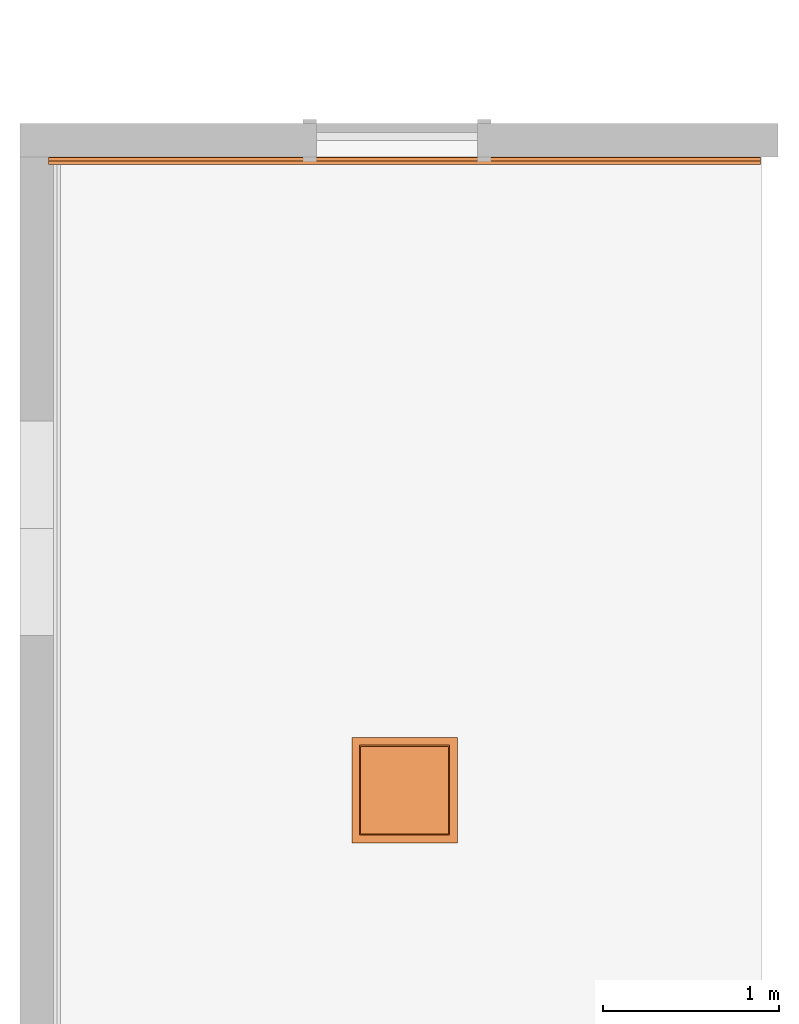
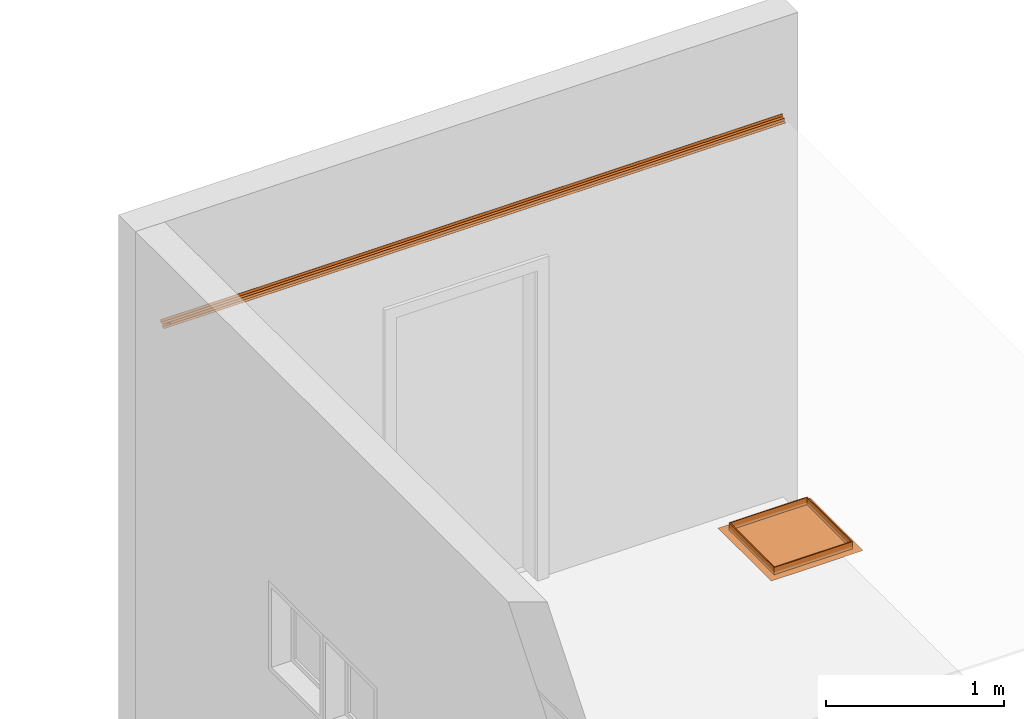
# One storey, part 5 of 5: 2 proxies.
"""IFC2X3 building model written with IfcOpenShell, lengths in millimetres."""

from ifc_helpers import new_model, entity, si_unit, converted_unit, derived_unit, direction, frame, origin, place, context, subcontext, project, spatial, faceted_brep, source, transform, mapped, material, type_object, type_shapes, element, save


model = new_model("IFC2X3")

# Units and contexts
model_context = context("Model", 3, precision=0.01, world=origin(), true_north=direction((6.12303176911189e-17, 1.0)))
body_context = subcontext(model_context, "Body", "Model", "MODEL_VIEW")
ifc_project = project(units=[si_unit("LENGTHUNIT", "METRE", prefix="MILLI"), si_unit("AREAUNIT", "SQUARE_METRE"), si_unit("VOLUMEUNIT", "CUBIC_METRE"), converted_unit("PLANEANGLEUNIT", "DEGREE", entity("IfcRatioMeasure", 0.0174532925199433), si_unit("PLANEANGLEUNIT", "RADIAN"), dimensions=[0, 0, 0, 0, 0, 0, 0]), si_unit("MASSUNIT", "GRAM", prefix="KILO"), derived_unit("MASSDENSITYUNIT", [(si_unit("MASSUNIT", "GRAM", prefix="KILO"), 1), (si_unit("LENGTHUNIT", "METRE"), -3)]), si_unit("TIMEUNIT", "SECOND"), si_unit("FREQUENCYUNIT", "HERTZ"), si_unit("THERMODYNAMICTEMPERATUREUNIT", "DEGREE_CELSIUS"), derived_unit("THERMALTRANSMITTANCEUNIT", [(si_unit("MASSUNIT", "GRAM", prefix="KILO"), 1), (si_unit("THERMODYNAMICTEMPERATUREUNIT", "KELVIN"), -1), (si_unit("TIMEUNIT", "SECOND"), -3)]), derived_unit("VOLUMETRICFLOWRATEUNIT", [(si_unit("LENGTHUNIT", "METRE"), 3), (si_unit("TIMEUNIT", "SECOND"), -1)]), si_unit("ELECTRICCURRENTUNIT", "AMPERE"), si_unit("ELECTRICVOLTAGEUNIT", "VOLT"), si_unit("POWERUNIT", "WATT"), si_unit("FORCEUNIT", "NEWTON", prefix="KILO"), si_unit("ILLUMINANCEUNIT", "LUX"), si_unit("LUMINOUSFLUXUNIT", "LUMEN"), si_unit("LUMINOUSINTENSITYUNIT", "CANDELA"), derived_unit("USERDEFINED", [(si_unit("MASSUNIT", "GRAM", prefix="KILO"), -1), (si_unit("LENGTHUNIT", "METRE"), -2), (si_unit("TIMEUNIT", "SECOND"), 3), (si_unit("LUMINOUSFLUXUNIT", "LUMEN"), 1)]), derived_unit("LINEARVELOCITYUNIT", [(si_unit("LENGTHUNIT", "METRE"), 1), (si_unit("TIMEUNIT", "SECOND"), -1)]), si_unit("PRESSUREUNIT", "PASCAL"), derived_unit("USERDEFINED", [(si_unit("LENGTHUNIT", "METRE"), -2), (si_unit("MASSUNIT", "GRAM", prefix="KILO"), 1), (si_unit("TIMEUNIT", "SECOND"), -2)])], contexts=[model_context])

# Site, building, storey
site_placement = place(None, origin())
site = spatial("IfcSite", under=ifc_project, at=site_placement, CompositionType="ELEMENT")
building_placement = place(site_placement, origin())
building = spatial("IfcBuilding", under=site, at=building_placement, CompositionType="ELEMENT")
storey_placement = place(building_placement, origin())
storey = spatial("IfcBuildingStorey", under=building, at=storey_placement, Name="Base Level", CompositionType="ELEMENT", Elevation=0.0)

# Proxies
ifc_material = material(Name="mesh")
building_element_proxy_type_1 = type_object("IfcBuildingElementProxyType", Name="Bottom Hung", PredefinedType="NOTDEFINED", material=ifc_material)
shared_shape_1 = source(origin(), body_context, "Body", "Brep", [
    faceted_brep([(50.8000000000058, 548.8, 59.5249999999756), (548.800000000014, 548.800000000001, 59.5249999999756), (548.800000000014, 50.8000000000014, 59.5249999999756), (50.8000000000058, 50.8000000000004, 59.5249999999756), (44.4499999999942, 555.149999999998, 59.5249999999756), (44.4499999999942, 44.4500000000045, 59.5249999999756), (555.150000000025, 44.4500000000056, 59.5249999999756), (555.150000000025, 555.149999999999, 59.5249999999756), (50.8000000000058, 548.8, 9.52499999997564), (50.8000000000058, 50.8000000000004, 9.52499999997564), (548.800000000014, 50.8000000000014, 9.52499999997564), (548.800000000014, 548.800000000001, 9.52499999997564), (44.4499999999942, 555.149999999998, 9.52499999997564), (555.150000000025, 555.149999999999, 9.52499999997564), (555.150000000025, 44.4500000000056, 9.52499999997564), (44.4499999999942, 44.4500000000045, 9.52499999997564), (44.4500000000115, 555.149999999999, 20.5249999999758), (44.4500000000115, 44.4500000000045, 20.5249999999758), (555.150000000025, 44.4500000000056, 20.5249999999758), (555.150000000025, 555.15, 20.5249999999758)], [[[0, 1, 2, 3], [4, 5, 6, 7]], [[8, 9, 10, 11], [12, 13, 14, 15]], [[1, 0, 8, 11]], [[2, 1, 11, 10]], [[3, 2, 10, 9]], [[0, 3, 9, 8]], [[5, 4, 16, 12, 15, 17]], [[6, 5, 17, 15, 14, 18]], [[7, 6, 18, 14, 13, 19]], [[4, 7, 19, 13, 12, 16]]], outer=[[False, True], [False, True], [True], [True], [True], [True], [True], [True], [True], [True]]),
    faceted_brep([(50.8000000000058, 548.8, 3.174999999976), (548.800000000014, 548.800000000001, 3.174999999976), (548.800000000014, 50.8000000000014, 3.174999999976), (50.8000000000058, 50.8000000000004, 3.174999999976), (50.8000000000058, 548.8, 9.52499999997564), (50.8000000000058, 50.8000000000004, 9.52499999997564), (548.800000000014, 50.8000000000014, 9.52499999997564), (548.800000000014, 548.800000000001, 9.52499999997564)], [[[0, 1, 2, 3]], [[4, 5, 6, 7]], [[5, 4, 0, 3]], [[6, 5, 3, 2]], [[7, 6, 2, 1]], [[4, 7, 1, 0]]]),
    faceted_brep([(50.8000000000231, 548.799999999992, 9.52499999995127), (50.8000000000231, 548.799999999992, 0.0), (548.800000000014, 548.799999999993, 0.0), (548.800000000014, 548.799999999993, 9.52499999995073), (548.800000000014, 50.8000000000096, 0.0), (548.800000000014, 50.8000000000096, 9.52499999995073), (50.8000000000231, 50.8000000000085, 0.0), (50.8000000000231, 50.8000000000085, 9.52499999995073), (586.900000000014, 586.900000000001, 0.0), (586.900000000014, 12.7000000000014, 0.0), (12.7000000000058, 12.7000000000004, 0.0), (12.7000000000058, 586.9, 0.0), (0.0, 599.6, 9.52499999995073), (0.0, 0.0, 9.52499999995073), (599.60000000002, 0.0, 9.52499999995073), (599.600000000037, 599.600000000001, 9.52499999995073)], [[[0, 1, 2, 3]], [[3, 2, 4, 5]], [[5, 4, 6, 7]], [[8, 9, 10, 11], [1, 6, 4, 2]], [[3, 5, 7, 0], [12, 13, 14, 15]], [[7, 6, 1, 0]], [[11, 12, 15, 8]], [[8, 15, 14, 9]], [[9, 14, 13, 10]], [[10, 13, 12, 11]]], outer=[[True], [True], [True], [True, False], [False, True], [True], [True], [True], [True], [True]]),
    faceted_brep([(149.460254037859, 122.150000000007, 9.52499999997564), (147.87106781188, 124.221067811872, 9.52499999997564), (145.800000000019, 125.810254037851, 9.52499999997564), (143.388190451048, 126.809258262898, 9.52499999997564), (140.80000000002, 127.150000000007, 9.52499999997564), (138.211809548992, 126.809258262898, 9.52499999997564), (135.800000000021, 125.810254037851, 9.52499999997564), (133.728932188159, 124.221067811872, 9.52499999997564), (132.139745962181, 122.150000000007, 9.52499999997564), (131.140741737132, 119.738190451032, 9.52499999997564), (130.800000000022, 117.150000000007, 9.52499999997564), (131.140741737132, 114.561809548982, 9.52499999997564), (132.139745962181, 112.150000000007, 9.52499999997564), (133.728932188159, 110.078932188141, 9.52499999997564), (135.800000000021, 108.489745962162, 9.52499999997564), (138.211809548992, 107.490741737116, 9.52499999997564), (140.80000000002, 107.150000000007, 9.52499999997564), (143.388190451048, 107.490741737116, 9.52499999997564), (145.800000000019, 108.489745962162, 9.52499999997564), (147.87106781188, 110.078932188141, 9.52499999997564), (149.460254037859, 112.150000000007, 9.52499999997564), (150.459258262908, 114.561809548982, 9.52499999997564), (150.800000000018, 117.150000000007, 9.52499999997564), (150.459258262908, 119.738190451032, 9.52499999997564), (131.140741737132, 119.738190451032, 3.174999999976), (132.139745962181, 122.150000000007, 3.174999999976), (133.728932188159, 124.221067811872, 3.174999999976), (135.800000000021, 125.810254037851, 3.174999999976), (138.211809548992, 126.809258262898, 3.174999999976), (140.80000000002, 127.150000000007, 3.174999999976), (143.388190451048, 126.809258262898, 3.174999999976), (145.800000000019, 125.810254037851, 3.174999999976), (147.87106781188, 124.221067811872, 3.174999999976), (149.460254037859, 122.150000000007, 3.174999999976), (150.459258262908, 119.738190451032, 3.174999999976), (150.800000000018, 117.150000000007, 3.174999999976), (150.459258262908, 114.561809548982, 3.174999999976), (149.460254037859, 112.150000000007, 3.174999999976), (147.87106781188, 110.078932188141, 3.174999999976), (145.800000000019, 108.489745962162, 3.174999999976), (143.388190451048, 107.490741737116, 3.174999999976), (140.80000000002, 107.150000000007, 3.174999999976), (138.211809548992, 107.490741737116, 3.174999999976), (135.800000000021, 108.489745962162, 3.174999999976), (133.728932188159, 110.078932188141, 3.174999999976), (132.139745962181, 112.150000000007, 3.174999999976), (131.140741737132, 114.561809548982, 3.174999999976), (130.800000000022, 117.150000000007, 3.174999999976)], [[[0, 1, 2, 3, 4, 5, 6, 7, 8, 9, 10, 11, 12, 13, 14, 15, 16, 17, 18, 19, 20, 21, 22, 23]], [[24, 25, 26, 27, 28, 29, 30, 31, 32, 33, 34, 35, 36, 37, 38, 39, 40, 41, 42, 43, 44, 45, 46, 47]], [[40, 17, 16, 41]], [[39, 18, 17, 40]], [[20, 19, 38, 37]], [[39, 38, 19, 18]], [[21, 20, 37, 36]], [[22, 21, 36, 35]], [[34, 23, 22, 35]], [[33, 0, 23, 34]], [[2, 1, 32, 31]], [[33, 32, 1, 0]], [[3, 2, 31, 30]], [[4, 3, 30, 29]], [[28, 5, 4, 29]], [[27, 6, 5, 28]], [[8, 7, 26, 25]], [[27, 26, 7, 6]], [[9, 8, 25, 24]], [[10, 9, 24, 47]], [[46, 11, 10, 47]], [[45, 12, 11, 46]], [[14, 13, 44, 43]], [[45, 44, 13, 12]], [[15, 14, 43, 42]], [[16, 15, 42, 41]]]),
    faceted_brep([(467.460254037856, 122.150000000009, 9.52499999997564), (465.871067811878, 124.221067811874, 9.52499999997564), (463.800000000016, 125.810254037853, 9.52499999997564), (461.388190451045, 126.809258262899, 9.52499999997564), (458.800000000017, 127.150000000008, 9.52499999997564), (456.211809548989, 126.809258262899, 9.52499999997564), (453.800000000018, 125.810254037853, 9.52499999997564), (451.728932188156, 124.221067811874, 9.52499999997564), (450.139745962178, 122.150000000009, 9.52499999997564), (449.140741737129, 119.738190451034, 9.52499999997564), (448.800000000019, 117.150000000009, 9.52499999997564), (449.140741737129, 114.561809548983, 9.52499999997564), (450.139745962178, 112.150000000008, 9.52499999997564), (451.728932188156, 110.078932188143, 9.52499999997564), (453.800000000018, 108.489745962164, 9.52499999997564), (456.211809548989, 107.490741737118, 9.52499999997564), (458.800000000017, 107.150000000008, 9.52499999997564), (461.388190451045, 107.490741737118, 9.52499999997564), (463.800000000016, 108.489745962164, 9.52499999997564), (465.871067811878, 110.078932188143, 9.52499999997564), (467.460254037856, 112.150000000008, 9.52499999997564), (468.459258262905, 114.561809548983, 9.52499999997564), (468.800000000015, 117.150000000009, 9.52499999997564), (468.459258262905, 119.738190451034, 9.52499999997564), (448.800000000019, 117.150000000009, 3.174999999976), (449.140741737129, 119.738190451034, 3.174999999976), (450.139745962178, 122.150000000009, 3.174999999976), (451.728932188156, 124.221067811874, 3.174999999976), (453.800000000018, 125.810254037853, 3.174999999976), (456.211809548989, 126.809258262899, 3.174999999976), (458.800000000017, 127.150000000008, 3.174999999976), (461.388190451045, 126.809258262899, 3.174999999976), (463.800000000016, 125.810254037853, 3.174999999976), (465.871067811878, 124.221067811874, 3.174999999976), (467.460254037856, 122.150000000009, 3.174999999976), (468.459258262905, 119.738190451034, 3.174999999976), (468.800000000015, 117.150000000009, 3.174999999976), (468.459258262905, 114.561809548983, 3.174999999976), (467.460254037856, 112.150000000008, 3.174999999976), (465.871067811878, 110.078932188143, 3.174999999976), (463.800000000016, 108.489745962164, 3.174999999976), (461.388190451045, 107.490741737118, 3.174999999976), (458.800000000017, 107.150000000008, 3.174999999976), (456.211809548989, 107.490741737118, 3.174999999976), (453.800000000018, 108.489745962164, 3.174999999976), (451.728932188156, 110.078932188143, 3.174999999976), (450.139745962178, 112.150000000008, 3.174999999976), (449.140741737129, 114.561809548983, 3.174999999976)], [[[0, 1, 2, 3, 4, 5, 6, 7, 8, 9, 10, 11, 12, 13, 14, 15, 16, 17, 18, 19, 20, 21, 22, 23]], [[24, 25, 26, 27, 28, 29, 30, 31, 32, 33, 34, 35, 36, 37, 38, 39, 40, 41, 42, 43, 44, 45, 46, 47]], [[41, 17, 16, 42]], [[40, 18, 17, 41]], [[20, 19, 39, 38]], [[40, 39, 19, 18]], [[21, 20, 38, 37]], [[22, 21, 37, 36]], [[35, 23, 22, 36]], [[34, 0, 23, 35]], [[2, 1, 33, 32]], [[34, 33, 1, 0]], [[3, 2, 32, 31]], [[4, 3, 31, 30]], [[29, 5, 4, 30]], [[28, 6, 5, 29]], [[8, 7, 27, 26]], [[28, 27, 7, 6]], [[9, 8, 26, 25]], [[10, 9, 25, 24]], [[47, 11, 10, 24]], [[46, 12, 11, 47]], [[14, 13, 45, 44]], [[46, 45, 13, 12]], [[15, 14, 44, 43]], [[16, 15, 43, 42]]]),
])
type_shapes(building_element_proxy_type_1, [shared_shape_1])
proxy_1_placement = place(building_placement, frame((107138.171271554, 2320.79895566311, 2590.47500000002)))
element("IfcBuildingElementProxy", 1, at=proxy_1_placement, inside=storey, type_object=building_element_proxy_type_1, material=ifc_material, Name="Ceiling_Access_HatchPanel_Parametric:Bottom Hung:2482", ObjectType="Ceiling_Access_HatchPanel_Parametric:Bottom Hung", context=body_context, shape_type="MappedRepresentation", body=[
    mapped(shared_shape_1, transform((0.0, 0.0, 0.0), scale=1.0)),
])
building_element_proxy_type_2 = type_object("IfcBuildingElementProxyType", Name="Systems Shadowline used with", PredefinedType="NOTDEFINED")
shared_shape_2 = source(origin(), body_context, "Body", "Brep", [
    faceted_brep([(4045.0, 41.0, 40.0), (4045.0, 40.0, 40.0), (4045.0, 40.0, 20.0), (4045.0, 20.0, 20.0), (4045.0, 20.0, 1.0), (4045.0, 0.0, 1.0), (4045.0, 0.0, 0.0), (4045.0, 21.0, 0.0), (4045.0, 21.0, 19.0), (4045.0, 41.0, 19.0), (0.0, 41.0, 40.0), (0.0, 41.0, 19.0), (0.0, 21.0, 19.0), (0.0, 21.0, 0.0), (0.0, 0.0, 0.0), (0.0, 0.0, 1.0), (0.0, 20.0, 1.0), (0.0, 20.0, 20.0), (0.0, 40.0, 20.0), (0.0, 40.0, 40.0), (28.0, 41.0, 19.0), (28.0, 41.0, 35.0), (27.0, 41.0, 35.0), (27.0, 41.0, 19.0), (28.0, 21.0, 19.0), (48.0, 21.0, 0.0), (48.0, 21.0, 15.0), (28.0, 21.0, 15.0), (48.0, 0.0, 0.0), (28.0, 20.0, 20.0), (28.0, 20.0, 15.0), (48.0, 20.0, 15.0), (48.0, 20.0, 1.0), (27.0, 40.0, 35.0), (27.0, 40.0, 20.0), (27.0, 20.0, 20.0), (27.0, 20.0, 14.0), (27.0, 21.0, 14.0), (27.0, 21.0, 19.0), (47.0, 20.0, 14.0), (47.0, 21.0, 14.0), (47.0, 20.0, 1.0), (47.0, 0.0, 1.0), (47.0, 0.0, 0.0), (47.0, 21.0, 0.0), (48.0, 0.0, 1.0), (28.0, 40.0, 20.0), (28.0, 40.0, 35.0)], [[[0, 1, 2, 3, 4, 5, 6, 7, 8, 9]], [[10, 11, 12, 13, 14, 15, 16, 17, 18, 19]], [[0, 9, 20, 21, 22, 23, 11, 10]], [[9, 8, 24, 20]], [[8, 7, 25, 26, 27, 24]], [[7, 6, 28, 25]], [[4, 3, 29, 30, 31, 32]], [[22, 33, 34, 35, 36, 37, 38, 23]], [[37, 36, 39, 40]], [[40, 39, 41, 42, 43, 44]], [[31, 26, 25, 28, 45, 32]], [[26, 31, 30, 27]], [[27, 30, 29, 46, 47, 21, 20, 24]], [[6, 5, 45, 28]], [[5, 4, 32, 45]], [[3, 2, 46, 29]], [[2, 1, 19, 18, 34, 33, 47, 46]], [[1, 0, 10, 19]], [[12, 11, 23, 38]], [[18, 17, 35, 34]], [[33, 22, 21, 47]], [[13, 12, 38, 37, 40, 44]], [[14, 13, 44, 43]], [[17, 16, 41, 39, 36, 35]], [[15, 14, 43, 42]], [[16, 15, 42, 41]]]),
])
type_shapes(building_element_proxy_type_2, [shared_shape_2])
proxy_2_placement = place(building_placement, frame((105415.734552934, 6176.91938039374, 2599.0)))
element("IfcBuildingElementProxy", 2, at=proxy_2_placement, inside=storey, type_object=building_element_proxy_type_2, Name="TR01:Systems Shadowline used with 2499", ObjectType="TR01:Systems Shadowline used with", context=body_context, shape_type="MappedRepresentation", body=[
    mapped(shared_shape_2, transform((0.0, 0.0, 0.0), scale=1.0)),
])

save(model, "model.ifc")
